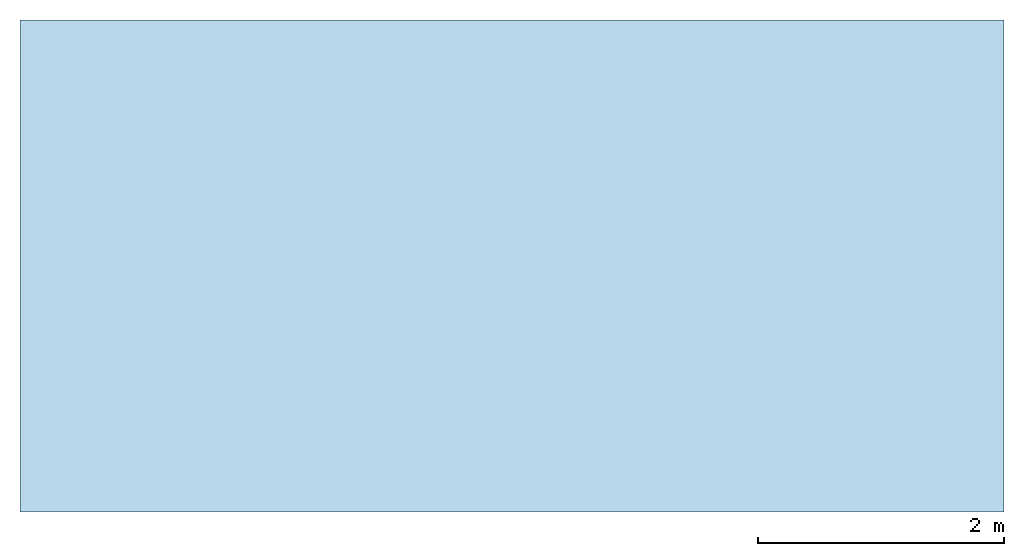
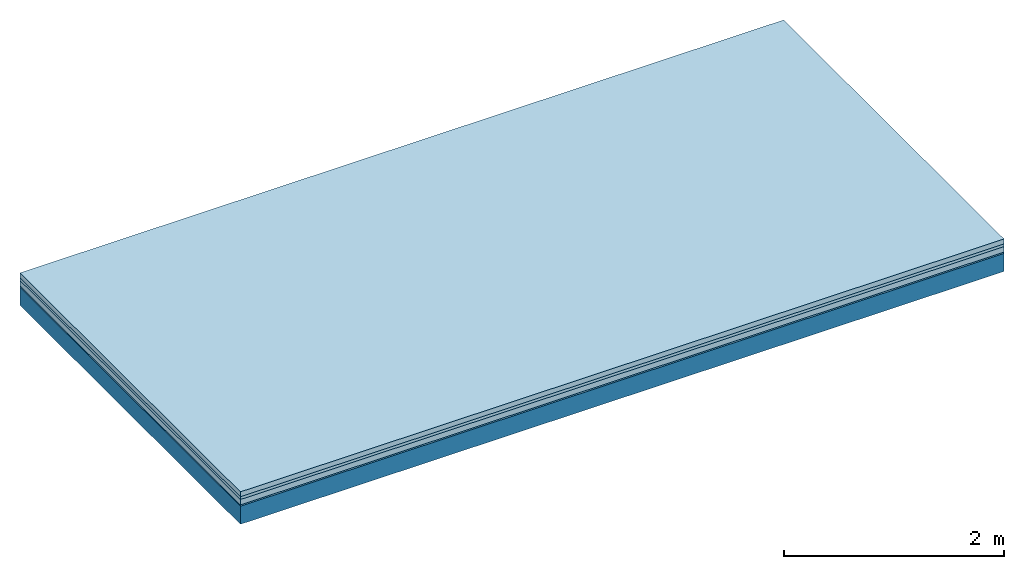
# One storey: 4 plates, 1 member, 1 element without a shape of its own.
"""IFC4 building model written with IfcOpenShell, lengths in metres."""

from ifc_helpers import new_model, si_unit, derived_unit, direction, frame, frame_2d, origin, origin_with_axes, place, context, project, spatial, rectangle, extrude, material, layer, layer_set, type_object, element, aggregate, save


model = new_model("IFC4")

# Units and contexts
plan_context = context("Plan", 3, precision=1e-05, world=origin(), true_north=direction((0.0, 1.0)))
model_context = context("Model", 3, precision=1e-05, world=origin(), true_north=direction((0.0, 1.0)))
ifc_project = project(units=[si_unit("LENGTHUNIT", "METRE"), derived_unit("SOUNDPRESSUREUNIT", [(si_unit("PRESSUREUNIT", "PASCAL", prefix="MICRO"), 0)]), si_unit("ENERGYUNIT", "JOULE", prefix="MEGA"), si_unit("MASSUNIT", "GRAM", prefix="KILO"), derived_unit("THERMALTRANSMITTANCEUNIT", [(si_unit("POWERUNIT", "WATT"), 1), (si_unit("AREAUNIT", "SQUARE_METRE"), -1), (si_unit("THERMODYNAMICTEMPERATUREUNIT", "KELVIN"), -1)]), derived_unit("AREADENSITYUNIT", [(si_unit("MASSUNIT", "GRAM", prefix="KILO"), 1), (si_unit("AREAUNIT", "SQUARE_METRE"), -1)]), derived_unit("USERDEFINED", [(si_unit("ENERGYUNIT", "JOULE", prefix="MEGA"), 1), (si_unit("AREAUNIT", "SQUARE_METRE"), -1)])], contexts=[plan_context, model_context])

# Site, building, storey
site = spatial("IfcSite", under=ifc_project)
building_placement = place(None, origin())
building = spatial("IfcBuilding", under=site, at=building_placement)
storey_placement = place(building_placement, origin())
storey = spatial("IfcBuildingStorey", under=building, at=storey_placement)

# Slab, member, plates
ifc_material_1 = material(Category="04.005")
ifc_layer_1 = layer(ifc_material_1, 0.055, Name="On-material")
ifc_material_2 = material()
ifc_layer_2 = layer(ifc_material_2, 0.03, Name="Impact sound insulation")
ifc_material_3 = material(Category="03.011")
ifc_layer_3 = layer(ifc_material_3, 0.06, Name="on Supporting structure")
ifc_material_4 = material(Category="03.007")
ifc_layer_4 = layer(ifc_material_4, 0.015, Name="Sub-floor")
ifc_material_5 = material(Name="of the art")
ifc_layer_5 = layer(ifc_material_5, 0.0, Name="Bond")
ifc_layer_6 = layer(None, 0.2, Name="Supporting structure")
ifc_layer_set = layer_set([ifc_layer_1, ifc_layer_2, ifc_layer_3, ifc_layer_4, ifc_layer_5, ifc_layer_6])
slab_type = type_object("IfcSlabType", Name="A1095", PredefinedType="NOTDEFINED", material=ifc_layer_set)
slab_placement = place(None, frame((0.0, 0.0, 0.0), z_axis=(0.0, 0.0, -1.0), x_axis=(1.0, 0.0, 0.0)))
slab = element("IfcSlab", 1, at=slab_placement, inside=storey, type_object=slab_type, material=ifc_layer_set, Name="Slab #1")
ifc_material_6 = material()
member_placement = place(slab_placement, origin())
member = element("IfcMember", 2, at=member_placement, material=ifc_material_6, Name="Supporting structure", context=plan_context, shape_type="SweptSolid", body=[
    extrude(rectangle(XDim=1.0, YDim=0.2, at=frame_2d((0.5, 0.1), x_axis=(1.0, 0.0))), frame((0.0, 4.0, 0.16), z_axis=(0.0, -1.0, 0.0), x_axis=(1.0, 0.0, 0.0)), (0.0, 0.0, 1.0), 4.0),
    extrude(rectangle(XDim=1.0, YDim=0.2, at=frame_2d((0.5, 0.1), x_axis=(1.0, 0.0))), frame((1.0, 4.0, 0.16), z_axis=(0.0, -1.0, 0.0), x_axis=(1.0, 0.0, 0.0)), (0.0, 0.0, 1.0), 4.0),
    extrude(rectangle(XDim=1.0, YDim=0.2, at=frame_2d((0.5, 0.1), x_axis=(1.0, 0.0))), frame((2.0, 4.0, 0.16), z_axis=(0.0, -1.0, 0.0), x_axis=(1.0, 0.0, 0.0)), (0.0, 0.0, 1.0), 4.0),
    extrude(rectangle(XDim=1.0, YDim=0.2, at=frame_2d((0.5, 0.1), x_axis=(1.0, 0.0))), frame((3.0, 4.0, 0.16), z_axis=(0.0, -1.0, 0.0), x_axis=(1.0, 0.0, 0.0)), (0.0, 0.0, 1.0), 4.0),
    extrude(rectangle(XDim=1.0, YDim=0.2, at=frame_2d((0.5, 0.1), x_axis=(1.0, 0.0))), frame((4.0, 4.0, 0.16), z_axis=(0.0, -1.0, 0.0), x_axis=(1.0, 0.0, 0.0)), (0.0, 0.0, 1.0), 4.0),
    extrude(rectangle(XDim=1.0, YDim=0.2, at=frame_2d((0.5, 0.1), x_axis=(1.0, 0.0))), frame((5.0, 4.0, 0.16), z_axis=(0.0, -1.0, 0.0), x_axis=(1.0, 0.0, 0.0)), (0.0, 0.0, 1.0), 4.0),
    extrude(rectangle(XDim=1.0, YDim=0.2, at=frame_2d((0.5, 0.1), x_axis=(1.0, 0.0))), frame((6.0, 4.0, 0.16), z_axis=(0.0, -1.0, 0.0), x_axis=(1.0, 0.0, 0.0)), (0.0, 0.0, 1.0), 4.0),
    extrude(rectangle(XDim=1.0, YDim=0.2, at=frame_2d((0.5, 0.1), x_axis=(1.0, 0.0))), frame((7.0, 4.0, 0.16), z_axis=(0.0, -1.0, 0.0), x_axis=(1.0, 0.0, 0.0)), (0.0, 0.0, 1.0), 4.0),
])
plate_1_placement = place(slab_placement, origin())
plate_1 = element("IfcPlate", 3, at=plate_1_placement, material=ifc_material_1, Name="On-material", context=plan_context, shape_type="SweptSolid", body=[
    extrude(rectangle(XDim=8.0, YDim=4.0, at=frame_2d((4.0, 2.0), x_axis=(1.0, 0.0))), origin_with_axes(), (0.0, 0.0, 1.0), 0.055),
])
plate_2_placement = place(slab_placement, origin())
plate_2 = element("IfcPlate", 4, at=plate_2_placement, material=ifc_material_2, Name="Impact sound insulation", context=plan_context, shape_type="SweptSolid", body=[
    extrude(rectangle(XDim=8.0, YDim=4.0, at=frame_2d((4.0, 2.0), x_axis=(1.0, 0.0))), frame((0.0, 0.0, 0.055), z_axis=(0.0, 0.0, 1.0), x_axis=(1.0, 0.0, 0.0)), (0.0, 0.0, 1.0), 0.03),
])
plate_3_placement = place(slab_placement, origin())
plate_3 = element("IfcPlate", 5, at=plate_3_placement, material=ifc_material_3, Name="on Supporting structure", context=plan_context, shape_type="SweptSolid", body=[
    extrude(rectangle(XDim=8.0, YDim=4.0, at=frame_2d((4.0, 2.0), x_axis=(1.0, 0.0))), frame((0.0, 0.0, 0.085), z_axis=(0.0, 0.0, 1.0), x_axis=(1.0, 0.0, 0.0)), (0.0, 0.0, 1.0), 0.06),
])
plate_4_placement = place(slab_placement, origin())
plate_4 = element("IfcPlate", 6, at=plate_4_placement, material=ifc_material_4, Name="Sub-floor", context=plan_context, shape_type="SweptSolid", body=[
    extrude(rectangle(XDim=8.0, YDim=4.0, at=frame_2d((4.0, 2.0), x_axis=(1.0, 0.0))), frame((0.0, 0.0, 0.145), z_axis=(0.0, 0.0, 1.0), x_axis=(1.0, 0.0, 0.0)), (0.0, 0.0, 1.0), 0.015),
])
aggregate(slab, [plate_1, plate_2, plate_3, plate_4, member])

save(model, "model.ifc")
